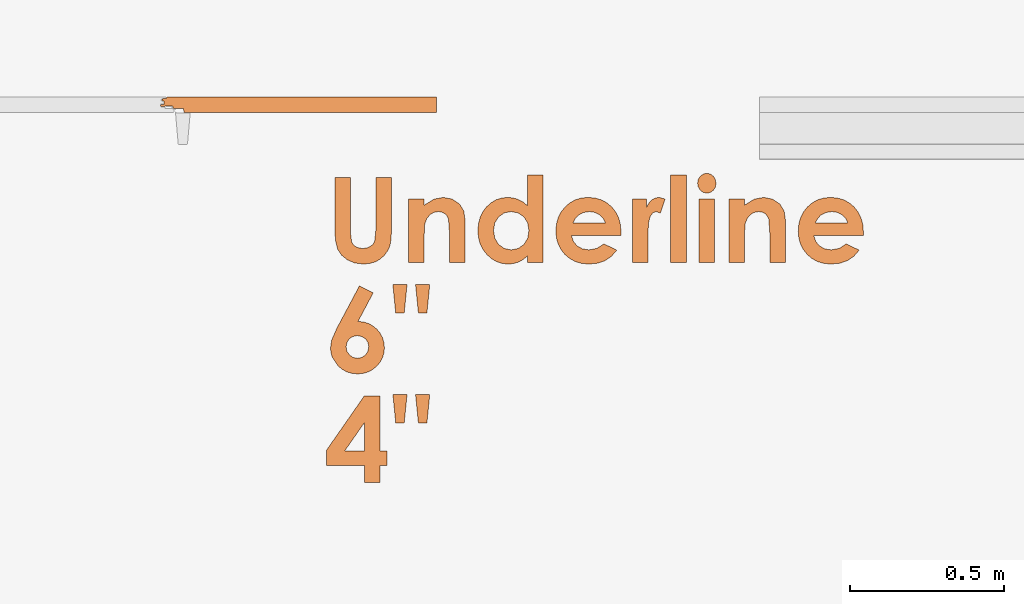
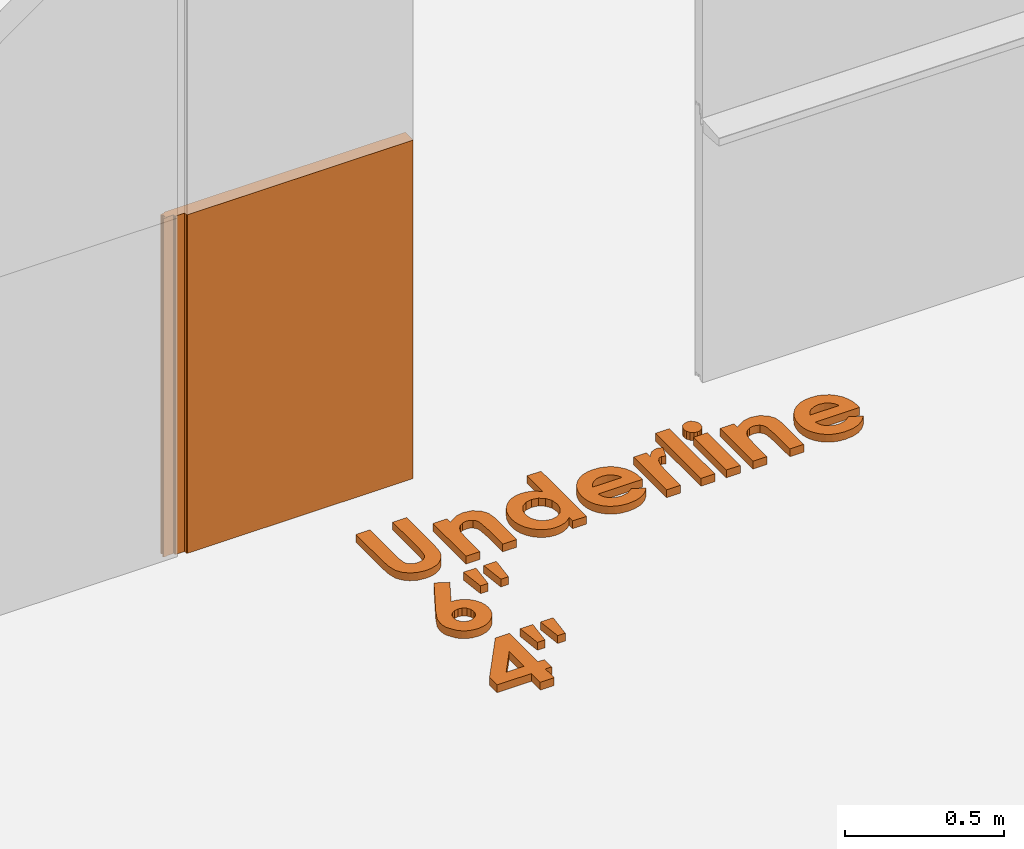
# One storey, part 4 of 6: 2 proxies.
"""IFC2X3 building model written with IfcOpenShell, lengths in millimetres."""

from ifc_helpers import new_model, entity, si_unit, converted_unit, derived_unit, direction, frame, frame_2d, origin, origin_2d_with_axis, place, context, subcontext, project, spatial, polyline, circle_curve, parameter, trimmed, segment, composite_curve, rectangle, outline, extrude, source, transform, mapped, material, type_object, type_shapes, element, save


model = new_model("IFC2X3")

# Units and contexts
model_context = context("Model", 3, precision=0.01, world=origin(), true_north=direction((6.123031769111886e-17, 1.0)))
body_context = subcontext(model_context, "Body", "Model", "MODEL_VIEW")
ifc_project = project(units=[si_unit("LENGTHUNIT", "METRE", prefix="MILLI"), si_unit("AREAUNIT", "SQUARE_METRE"), si_unit("VOLUMEUNIT", "CUBIC_METRE"), converted_unit("PLANEANGLEUNIT", "DEGREE", entity("IfcPlaneAngleMeasure", 0.017453292519943278), si_unit("PLANEANGLEUNIT", "RADIAN"), dimensions=[0, 0, 0, 0, 0, 0, 0]), si_unit("MASSUNIT", "GRAM", prefix="KILO"), derived_unit("MASSDENSITYUNIT", [(si_unit("MASSUNIT", "GRAM", prefix="KILO"), 1), (si_unit("LENGTHUNIT", "METRE"), -3)]), derived_unit("IONCONCENTRATIONUNIT", [(si_unit("MASSUNIT", "GRAM", prefix="KILO"), 1), (si_unit("LENGTHUNIT", "METRE"), -3)]), derived_unit("MOMENTOFINERTIAUNIT", [(si_unit("LENGTHUNIT", "METRE"), 4)]), si_unit("TIMEUNIT", "SECOND"), si_unit("FREQUENCYUNIT", "HERTZ"), si_unit("THERMODYNAMICTEMPERATUREUNIT", "DEGREE_CELSIUS"), derived_unit("THERMALTRANSMITTANCEUNIT", [(si_unit("MASSUNIT", "GRAM", prefix="KILO"), 1), (si_unit("THERMODYNAMICTEMPERATUREUNIT", "KELVIN"), -1), (si_unit("TIMEUNIT", "SECOND"), -3)]), derived_unit("THERMALCONDUCTANCEUNIT", [(si_unit("MASSUNIT", "GRAM", prefix="KILO"), 1), (si_unit("THERMODYNAMICTEMPERATUREUNIT", "KELVIN"), -1), (si_unit("TIMEUNIT", "SECOND"), -3), (si_unit("LENGTHUNIT", "METRE"), 1)]), derived_unit("VOLUMETRICFLOWRATEUNIT", [(si_unit("LENGTHUNIT", "METRE", prefix="DECI"), 3), (si_unit("TIMEUNIT", "SECOND"), -1)]), derived_unit("MASSFLOWRATEUNIT", [(si_unit("MASSUNIT", "GRAM", prefix="KILO"), 1), (si_unit("TIMEUNIT", "SECOND"), -1)]), derived_unit("ROTATIONALFREQUENCYUNIT", [(si_unit("TIMEUNIT", "SECOND"), -1)]), si_unit("ELECTRICCURRENTUNIT", "AMPERE"), si_unit("ELECTRICVOLTAGEUNIT", "VOLT"), si_unit("POWERUNIT", "WATT"), si_unit("FORCEUNIT", "NEWTON", prefix="KILO"), si_unit("ILLUMINANCEUNIT", "LUX"), si_unit("LUMINOUSFLUXUNIT", "LUMEN"), si_unit("LUMINOUSINTENSITYUNIT", "CANDELA"), si_unit("ENERGYUNIT", "JOULE"), derived_unit("USERDEFINED", [(si_unit("MASSUNIT", "GRAM", prefix="KILO"), -1), (si_unit("LENGTHUNIT", "METRE"), -2), (si_unit("TIMEUNIT", "SECOND"), 3), (si_unit("LUMINOUSFLUXUNIT", "LUMEN"), 1)]), derived_unit("USERDEFINED", [(si_unit("MASSUNIT", "GRAM", prefix="KILO"), 1), (si_unit("TIMEUNIT", "SECOND"), -3), (si_unit("LENGTHUNIT", "METRE"), 3), (si_unit("ELECTRICCURRENTUNIT", "AMPERE"), -2)]), derived_unit("SOUNDPOWERUNIT", [(si_unit("MASSUNIT", "GRAM", prefix="KILO"), 1), (si_unit("TIMEUNIT", "SECOND"), -3), (si_unit("LENGTHUNIT", "METRE"), 2)]), derived_unit("SOUNDPRESSUREUNIT", [(si_unit("MASSUNIT", "GRAM", prefix="KILO"), 1), (si_unit("LENGTHUNIT", "METRE"), -1), (si_unit("TIMEUNIT", "SECOND"), -2)]), derived_unit("LINEARVELOCITYUNIT", [(si_unit("LENGTHUNIT", "METRE"), 1), (si_unit("TIMEUNIT", "SECOND"), -1)]), si_unit("PRESSUREUNIT", "PASCAL"), derived_unit("USERDEFINED", [(si_unit("MASSUNIT", "GRAM", prefix="KILO"), 1), (si_unit("LENGTHUNIT", "METRE"), -2), (si_unit("TIMEUNIT", "SECOND"), -2)]), derived_unit("LINEARFORCEUNIT", [(si_unit("MASSUNIT", "GRAM", prefix="KILO"), 1), (si_unit("TIMEUNIT", "SECOND"), -2)]), derived_unit("PLANARFORCEUNIT", [(si_unit("MASSUNIT", "GRAM", prefix="KILO"), 1), (si_unit("LENGTHUNIT", "METRE"), -1), (si_unit("TIMEUNIT", "SECOND"), -2)]), derived_unit("SPECIFICHEATCAPACITYUNIT", [(si_unit("THERMODYNAMICTEMPERATUREUNIT", "KELVIN"), -1), (si_unit("LENGTHUNIT", "METRE"), 2), (si_unit("TIMEUNIT", "SECOND"), -2)]), derived_unit("HEATFLUXDENSITYUNIT", [(si_unit("MASSUNIT", "GRAM", prefix="KILO"), 1), (si_unit("TIMEUNIT", "SECOND"), -3)]), derived_unit("HEATINGVALUEUNIT", [(si_unit("LENGTHUNIT", "METRE"), 2), (si_unit("TIMEUNIT", "SECOND"), -2)]), derived_unit("VAPORPERMEABILITYUNIT", [(si_unit("LENGTHUNIT", "METRE"), -1), (si_unit("TIMEUNIT", "SECOND"), 1)]), derived_unit("DYNAMICVISCOSITYUNIT", [(si_unit("MASSUNIT", "GRAM", prefix="KILO"), 1), (si_unit("TIMEUNIT", "SECOND"), -1), (si_unit("LENGTHUNIT", "METRE"), -1)]), derived_unit("THERMALEXPANSIONCOEFFICIENTUNIT", [(si_unit("THERMODYNAMICTEMPERATUREUNIT", "KELVIN"), -1)]), derived_unit("MODULUSOFELASTICITYUNIT", [(si_unit("MASSUNIT", "GRAM", prefix="KILO"), 1), (si_unit("LENGTHUNIT", "METRE"), -1), (si_unit("TIMEUNIT", "SECOND"), -2)]), derived_unit("ISOTHERMALMOISTURECAPACITYUNIT", [(si_unit("MASSUNIT", "GRAM", prefix="KILO"), -1), (si_unit("LENGTHUNIT", "METRE"), 3)]), derived_unit("MOISTUREDIFFUSIVITYUNIT", [(si_unit("TIMEUNIT", "SECOND"), -1), (si_unit("LENGTHUNIT", "METRE"), 2)]), derived_unit("MASSPERLENGTHUNIT", [(si_unit("MASSUNIT", "GRAM", prefix="KILO"), 1), (si_unit("LENGTHUNIT", "METRE"), -1)]), derived_unit("THERMALRESISTANCEUNIT", [(si_unit("MASSUNIT", "GRAM", prefix="KILO"), -1), (si_unit("TIMEUNIT", "SECOND"), 3), (si_unit("THERMODYNAMICTEMPERATUREUNIT", "KELVIN"), 1)]), derived_unit("ACCELERATIONUNIT", [(si_unit("LENGTHUNIT", "METRE"), 1), (si_unit("TIMEUNIT", "SECOND"), -2)]), derived_unit("ANGULARVELOCITYUNIT", [(si_unit("TIMEUNIT", "SECOND"), -1), (si_unit("PLANEANGLEUNIT", "RADIAN"), 1)]), derived_unit("LINEARSTIFFNESSUNIT", [(si_unit("MASSUNIT", "GRAM", prefix="KILO"), 1), (si_unit("TIMEUNIT", "SECOND"), -2)]), derived_unit("WARPINGCONSTANTUNIT", [(si_unit("LENGTHUNIT", "METRE"), 6)]), derived_unit("LINEARMOMENTUNIT", [(si_unit("MASSUNIT", "GRAM", prefix="KILO"), 1), (si_unit("LENGTHUNIT", "METRE"), 1), (si_unit("TIMEUNIT", "SECOND"), -2)]), derived_unit("TORQUEUNIT", [(si_unit("MASSUNIT", "GRAM", prefix="KILO"), 1), (si_unit("LENGTHUNIT", "METRE"), 2), (si_unit("TIMEUNIT", "SECOND"), -2)])], contexts=[model_context])

# Site, building, storey
site_placement = place(None, origin())
site = spatial("IfcSite", under=ifc_project, at=site_placement, CompositionType="ELEMENT")
building_placement = place(site_placement, origin())
building = spatial("IfcBuilding", under=site, at=building_placement, Name="de", CompositionType="ELEMENT")
storey_placement = place(building_placement, origin())
storey = spatial("IfcBuildingStorey", under=building, at=storey_placement, CompositionType="ELEMENT", Elevation=0.0)

# Proxies
building_element_proxy_type_1 = type_object("IfcBuildingElementProxyType", Name="Texto do modelo:280mm Arial", PredefinedType="NOTDEFINED")
proxy_1_placement = place(storey_placement, origin())
element("IfcBuildingElementProxy", 1, at=proxy_1_placement, inside=storey, type_object=building_element_proxy_type_1, Name="Texto do modelo:280mm Arial", ObjectType="Texto do modelo:280mm Arial", context=body_context, shape_type="SweptSolid", body=[
    extrude(outline(polyline([(-197.135076634808, -96.36871776231979), (-33.485153354831525, -96.36871776231979), (8.490691504096427, -94.00768913350116), (36.228272112894174, -86.92460324704406), (55.12551270309856, -74.35347753253053), (70.58033750624617, -55.52832941954201), (80.88055018846063, -31.638684782140214), (84.31395441586547, -3.8740694943865037), (82.52065404512129, 17.31210724742106), (77.14075293288862, 35.74074673572234), (68.02105456508377, 51.79033447590066), (55.00836242762312, 65.83935597333932), (39.7788266157751, 76.78840095049625), (24.008597224808227, 83.53805912983013), (1.6148714896352496, 87.0255327151469), (-33.48515335483111, 88.18802391025248), (-197.13507663480766, 88.18802391025248), (-197.13507663480766, 37.43491995029546), (-26.27590563324637, 37.43491995029546), (11.104043803171214, 33.505879942031214), (20.0164762989805, 27.99981699467074), (27.21671246091335, 19.339708169116868), (31.974815957159343, 8.129327962052434), (33.56085045590794, -5.027549129839993), (32.137024030894906, -17.454489889921938), (27.865544755855876, -27.916910645871965), (21.224025292345775, -36.05434901161082), (12.690078301919677, -41.506342601059366), (-19.71549020660429, -45.61561380236263), (-197.13507663480794, -45.61561380236263), (-197.135076634808, -96.36871776231979)])), frame((-964.6189133034394, 358.32084995710176, 0.0), z_axis=(0.0, 0.0, 1.0), x_axis=(0.0, -1.0, 0.0)), (0.0, 0.0, 1.0), 30.0),
    extrude(outline(polyline([(-71.39783615934202, -98.70323738649664), (136.2284982223022, -98.70323738649664), (136.2284982223022, -47.950133426539615), (52.52913217470197, -47.950133426539615), (10.138755571782912, -45.571081678416384), (-6.577687582641928, -39.299036160637435), (-19.238928893675357, -29.422366782066188), (-27.214159185678575, -16.589905837645162), (-29.872569283012982, -1.4504856223168858), (-28.268511664960318, 10.147391649782836), (-23.4563388108024, 19.708656440534785), (-15.580235674970927, 26.971973520031455), (-4.784387211897605, 31.676007658365595), (44.81523711260633, 35.10040032611834), (136.2284982223025, 35.10040032611834), (136.2284982223025, 85.85350428607563), (-0.5309310561623658, 85.85350428607563), (-31.909181764360483, 81.27563198286954), (-54.52819649083311, 67.54201507325044), (-70.64086514857532, 43.33696584802934), (-76.01175470115618, 14.409859365169904), (-70.4245877169279, -15.436426202191265), (-50.56311024396169, -47.95013342653921), (-71.39783615934196, -47.95013342653921), (-71.39783615934202, -98.70323738649664)])), frame((-722.3606295049182, 414.84931230535244, 0.0), z_axis=(0.0, 0.0, 1.0), x_axis=(0.0, -1.0, 0.0)), (0.0, 0.0, 1.0), 30.0),
    extrude(outline(polyline([(-176.88914738248164, -74.5128578409968), (-176.88914738248155, -125.26596180095369), (109.17380221000593, -125.26596180095369), (109.17380221000593, -74.51285784099612), (87.69024399968303, -74.51285784099612), (99.60352585960199, -59.35541450636392), (107.65986018847306, -44.16192493312386), (112.25575561098339, -28.30157994563707), (113.78772075182013, -11.143570368265157), (111.85023542664413, 8.118638387844397), (106.0377794511163, 26.038124755808802), (96.3503528252366, 42.61488873562806), (82.78795554900499, 57.84893032730203), (66.34636496396548, 70.59127567520328), (48.02135841166193, 79.69295092370415), (27.81293589209434, 85.1539560728046), (5.721097405262716, 86.97429112250475), (-17.06688406468445, 85.21253121054244), (-37.70560855763416, 79.92725147465544), (-56.195076073586264, 71.11845191484387), (-72.53528661254099, 58.78613253110769), (-85.89267090668989, 43.939588004468874), (-95.43365968822485, 27.588113015949066), (-101.1582529571458, 9.73170756554855), (-103.06645071345274, -9.629628346732817), (-101.3722774988803, -27.598678292783028), (-96.28975785516296, -44.45029484198767), (-87.81889178230068, -60.112385517130704), (-75.95967928029351, -74.5128578409968), (-176.88914738248164, -74.5128578409968)]), holes=[polyline([(-56.92726529530953, -20.948147269620893), (-52.583693543054785, 1.5627287410278248), (-39.552978286290134, 19.928287311765285), (-19.727547051931783, 32.14796219985171), (5.000172633104336, 36.22118716254725), (29.908123511180083, 32.07586972263599), (49.98587841579391, 19.63991740290215), (63.23287110420619, 1.1481969970369155), (67.64853533367699, -21.164424701268178), (63.30496358142218, -44.04477465764818), (50.27424832465753, -62.653645338989165), (30.21451653934769, -75.00849362185525), (4.783895201457053, -79.12677638281076), (-20.142078795922625, -75.0084936218554), (-39.84134819515334, -62.6536453389893), (-52.655786020270504, -43.99070529973667), (-56.92726529530953, -20.948147269620893)])]), frame((-508.0075672200088, 387.79461629305536, 0.0), z_axis=(0.0, 0.0, -1.0), x_axis=(0.0, -1.0, 0.0)), (0.0, 0.0, -1.0), 30.0),
    extrude(outline(polyline([(-8.11404073497101, -112.03894976959059), (1.83707168478397, -112.03894976959056), (26.371906783790156, -109.63524336608025), (48.298315745056215, -103.54756103241345), (67.61629856858222, -93.77590276859067), (84.32585525436811, -80.32026857461125), (97.74060425866037, -63.948222802015096), (107.17416403770528, -45.427329802341696), (112.626534591503, -24.757589575590927), (114.09771592005353, -1.9390021217627762), (111.68181740608563, 19.528660321923912), (105.41027412957447, 39.02864344493145), (95.28308609052006, 56.56094724725969), (81.3002532889224, 72.12557172890877), (64.42784134457433, 84.8196152158297), (45.63191587726898, 93.74017603397405), (24.91247688700634, 98.88725418334141), (2.2695243737863007, 100.2608496639319), (-19.751728434694087, 97.91403977589047), (-39.75927548141036, 91.87483209825997), (-57.75311676636253, 82.14322663104068), (-73.73325228955056, 68.71922337423254), (-86.77033965545135, 52.389188970201), (-95.93503646854181, 33.93949006131208), (-101.22734272882185, 13.370126647565675), (-102.64725843629154, -9.31890127103823), (-99.26088751561832, -37.80065058597299), (-90.4336036871196, -61.981767588811785), (-75.92019374127064, -82.36168812962447), (-55.47544446854666, -99.43984805848197), (-35.92262886688955, -56.83072333122315), (-51.053380694864686, -35.00400568277521), (-56.503303033711035, -9.03686690864556), (-53.84238716741448, 12.437503644007833), (-44.8380484336359, 29.867423097071715), (-30.445286520588205, 42.402871219445984), (-11.619101116484497, 49.193827780030404), (-8.11404073497101, -112.03894976959059)]), holes=[polyline([(32.30305025346912, -60.611550644853786), (29.996635912124393, 45.483509056997775), (45.60841301373618, 37.18778165873086), (55.757341201558404, 28.088256327644583), (64.76912250878897, 11.590812985241655), (68.06970797756777, -7.554619648514906), (65.8874670985544, -25.340999198491758), (58.51971109543776, -40.93260300890451), (46.98528910236147, -53.099447888207074), (32.30305025346912, -60.611550644853786)])]), frame((-241.02849744432936, 376.8324445053329, 0.0), z_axis=(0.0, 0.0, 1.0), x_axis=(0.021733995409216757, 0.9997637888239163, 0.0)), (0.0, 0.0, 1.0), 30.0),
    extrude(outline(polyline([(-56.439928192101945, -57.358047093115275), (151.18640618954225, -57.358047093115275), (151.18640618954225, -6.604943133158253), (67.84750252802124, -6.604943133158253), (57.82664819501829, -6.821220564805537), (21.744363348486033, -4.8927467992816105), (-0.13570348652401948, 0.8926744972903038), (-11.219921858460749, 9.453656166672568), (-14.91466131577297, 19.70881105062687), (-10.37283525117446, 33.69475163050152), (-55.64691094272738, 48.762079368613946), (-61.0538467339161, 29.729665383629957), (-59.00822269291643, 17.40185177971989), (-52.8713505699173, 6.083332856831612), (-42.78741531935052, -3.6491515673080706), (-28.900601895647686, -11.218861674972208), (-56.43992819210188, -11.218861674972208), (-56.439928192101945, -57.358047093115275)])), frame((-34.706690191637534, 429.80722027259094, 0.0), z_axis=(0.0, 0.0, 1.0), x_axis=(0.0, -1.0, 0.0)), (0.0, 0.0, 1.0), 30.0),
    extrude(rectangle(XDim=286.0629495924876, YDim=50.75310395995675, at=frame_2d((-2.842170943040401e-14, 0.0), x_axis=(1.0, 0.0))), frame((57.88761532421236, 421.65228887929214, 0.0), z_axis=(0.0, 0.0, 1.0), x_axis=(0.0, -1.0, 0.0)), (0.0, 0.0, 1.0), 30.0),
    extrude(outline(polyline([(-6.301712198753567, -31.60790630917671), (5.420899933632481, -31.60790630917671), (16.281580658394684, -26.689281867233216), (24.754440796515407, -17.940784070354724), (29.31359116897778, -6.451164005550097), (29.653716775795946, 6.407063642744563), (25.240729387126496, 18.130818809981875), (17.074846845138385, 27.12018522368942), (6.156286992001091, 31.775246611394653), (-5.412701256381329, 31.71657774984953), (-16.236472346675033, 26.70773668446727), (-24.732567265953474, 17.844415841171212), (-29.318527001289805, 6.22230764588482), (-29.63184324523399, -6.503431871928007), (-25.19562107540711, -18.112363992747763), (-17.066648167887497, -27.011513783016547), (-6.301712198753567, -31.60790630917671)])), frame((150.18626216971575, 537.0678391220397, 0.0), z_axis=(0.0, 0.0, 1.0), x_axis=(-0.9801346684953595, -0.19833313291906599, 0.0)), (0.0, 0.0, 1.0), 30.0),
    extrude(rectangle(XDim=207.62633438164426, YDim=50.75310395995702, at=origin_2d_with_axis()), frame((150.1659861604985, 382.4339812738703, 0.0), z_axis=(0.0, 0.0, 1.0), x_axis=(0.0, -1.0, 0.0)), (0.0, 0.0, 1.0), 30.0),
    extrude(outline(polyline([(-71.39783615934189, -98.70323738649637), (136.22849822230225, -98.70323738649637), (136.22849822230225, -47.950133426539615), (52.52913217470204, -47.950133426539615), (10.138755571783047, -45.571081678416114), (-6.57768758264186, -39.299036160637435), (-19.23892889367529, -29.422366782066188), (-27.214159185678508, -16.589905837645162), (-29.872569283012915, -1.4504856223168858), (-28.26851166496025, 10.147391649782836), (-23.456338810802333, 19.708656440534785), (-15.58023567497086, 26.971973520031455), (-4.784387211897537, 31.676007658365595), (44.815237112606404, 35.10040032611834), (136.22849822230256, 35.10040032611834), (136.22849822230256, 85.85350428607563), (-0.5309310561622981, 85.85350428607563), (-31.909181764360415, 81.27563198286954), (-54.52819649083305, 67.54201507325071), (-70.64086514857524, 43.33696584802961), (-76.01175470115605, 14.409859365170174), (-70.42458771692783, -15.436426202191265), (-50.56311024396162, -47.950133426539075), (-71.39783615934189, -47.950133426539075), (-71.39783615934189, -98.70323738649637)])), frame((320.38496094511726, 414.8493123053502, 0.0), z_axis=(0.0, 0.0, 1.0), x_axis=(0.0, -1.0, 0.0)), (0.0, 0.0, 1.0), 30.0),
    extrude(outline(polyline([(-8.114040734969551, -112.03894976959074), (1.8370716847854303, -112.03894976959074), (26.371906783791587, -109.63524336608019), (48.29831574505763, -103.54756103241314), (67.61629856858343, -93.77590276858986), (84.32585525436912, -80.32026857461013), (97.74060425866115, -63.94822280201382), (107.17416403770582, -45.42732980234031), (112.62653459150333, -24.75758957558961), (114.09771592005346, -1.9390021217617182), (111.68181740608529, 19.52866032192508), (105.41027412957395, 39.02864344493254), (95.28308609051923, 56.56094724726067), (81.30025328892135, 72.12557172890973), (64.42784134457311, 84.81961521583062), (45.63191587726764, 93.74017603397449), (24.91247688700493, 98.88725418334161), (2.269524373784868, 100.26084966393199), (-19.751728434695483, 97.91403977589019), (-39.759275481411684, 91.87483209825974), (-57.75311676636372, 82.14322663104008), (-73.73325228955156, 68.71922337423179), (-86.77033965545212, 52.38918897020023), (-95.93503646854226, 33.93949006131109), (-101.22734272882205, 13.370126647564621), (-102.64725843629147, -9.318901271039435), (-99.26088751561785, -37.80065058597402), (-90.43360368711878, -61.981767588812716), (-75.92019374126957, -82.36168812962552), (-55.47544446854537, -99.43984805848265), (-35.92262886688884, -56.830723331223616), (-51.05338069486428, -35.0040056827753), (-56.50330303371098, -9.036866908646118), (-53.84238716741472, 12.437503644007439), (-44.83804843363637, 29.867423097071146), (-30.445286520588848, 42.40287121944554), (-11.619101116485231, 49.19382778003008), (-8.114040734969551, -112.03894976959074)]), holes=[polyline([(32.30305025346987, -60.6115506448535), (29.9966359121237, 45.48350905699814), (45.60841301373561, 37.1877816587313), (55.757341201557956, 28.0882563276454), (64.76912250878873, 11.590812985242573), (68.0697079775678, -7.554619648514087), (65.88746709855467, -25.340999198490827), (58.51971109543825, -40.93260300890366), (46.98528910236219, -53.09944788820649), (32.30305025346987, -60.6115506448535)])]), frame((547.9515732059187, 376.8324445053312, 0.0), z_axis=(0.0, 0.0, 1.0), x_axis=(0.02173399540923035, 0.9997637888239159, 0.0)), (0.0, 0.0, 1.0), 30.0),
    extrude(outline(polyline([(-169.66183796967937, -98.99477912253916), (-15.146399701648281, -98.99477912253886), (27.878495229872524, -95.89960184133162), (52.121628786830605, -87.28397024366502), (65.6659704647548, -78.29373765017078), (76.89738450283843, -66.9717831427635), (92.421429659484, -37.332708386209944), (96.07797130501153, -20.23717390641826), (96.14940636462921, -3.25308905142279), (92.6357348383373, 13.619546178776623), (85.53695672613557, 30.38073178417967), (76.01873011613868, 44.989019629840946), (64.39991962930331, 56.99395784681484), (50.680525265629285, 66.39554643510155), (34.860547025116794, 73.19378539470105), (18.146112702035733, 76.96384004086377), (1.743350090656581, 77.28087568884037), (-14.347740809020715, 74.14489233863046), (-30.127159996996397, 67.55588999023439), (-44.92453947273135, 57.90384352385236), (-56.9239939241664, 46.188419116038254), (-66.12552335130152, 32.409616766792276), (-72.52912775413677, 16.56743647611421), (-75.85604852554286, -0.17401198811110782), (-75.82752705839061, -16.650618857999227), (-72.44356335268003, -32.862384133549995), (-65.70415740841104, -48.80930781476339), (-171.61654338207018, -48.82945594929495), (-169.66183796967937, -98.99477912253916)]), holes=[polyline([(-23.856885622150433, -29.23151012664523), (-28.502115401814958, -14.941580255402522), (-27.263265809341423, -0.5824437284030344), (-20.65922699055348, 12.058870921159274), (-9.208889091274667, 21.195335160090508), (5.061279462710555, 25.6667115977814), (19.48841173921792, 23.97404545675935), (32.171292427590174, 17.004207837394425), (41.208706217170366, 5.644069840056746), (45.25258229454968, -7.669449140961902), (43.700028097418254, -21.899506425450323), (36.96857923674712, -34.7617610110216), (25.47577132350722, -43.97187189528907), (11.540094598120449, -48.438762093508984), (-2.5199606989916377, -47.07135462093718), (-14.915314221268666, -40.46911534338025), (-23.856885622150433, -29.23151012664523)])]), frame((-973.29051186755, 6.128888372974831, 0.0), z_axis=(0.0, 0.0, 1.0), x_axis=(-0.4698373532774691, -0.8827530013912287, 0.0)), (0.0, 0.0, 1.0), 30.0),
    extrude(outline(polyline([(-44.53289925453546, -18.36408216681859), (48.205715687899236, -18.36408216681859), (43.61469514619443, 27.546123250228316), (-47.287511579558306, 9.18204108340953), (-44.53289925453546, -18.36408216681859)])), frame((-848.7473781423013, 160.88456319715382, 0.0), z_axis=(0.0, 0.0, 1.0), x_axis=(0.09950371902100134, 0.9950371902099889, 0.0)), (0.0, 0.0, 1.0), 30.0),
    extrude(outline(polyline([(-44.53289925453539, -18.36408216681879), (48.20571568789929, -18.36408216681879), (43.61469514619446, 27.546123250228117), (-47.28751157955828, 9.182041083409331), (-44.53289925453539, -18.36408216681879)])), frame((-774.9246814732725, 160.88456319715362, 0.0), z_axis=(0.0, 0.0, 1.0), x_axis=(0.09950371902100281, 0.9950371902099888, 0.0)), (0.0, 0.0, 1.0), 30.0),
    extrude(outline(polyline([(-143.95272402011778, -112.24896765787754), (72.83533661905689, -112.24896765787754), (112.35981574631157, -84.73557416491812), (41.18744455494363, 17.50738980498599), (86.62876187490123, 49.13955477892745), (57.632610648788415, 90.7940956555551), (12.191293328831039, 59.16193068161378), (-0.9887754103112381, 78.09581289826278), (-38.85653984360908, 51.73567541997834), (-25.676471104466877, 32.80179320332946), (-173.36075239432859, -70.00274296197995), (-143.95272402011778, -112.24896765787754)]), holes=[polyline([(3.3196801216458223, -8.852747673298262), (40.55337430972267, -62.34096493533157), (-73.5400480015635, -62.35558921125364), (3.3196801216458223, -8.852747673298262)])]), frame((-954.9330432196826, -337.526182834684, 0.0), z_axis=(0.0, 0.0, 1.0), x_axis=(-0.5713177907106903, -0.8207289333375887, 0.0)), (0.0, 0.0, 1.0), 29.999999999999975),
    extrude(outline(polyline([(-44.532899254535444, -18.364082166818722), (48.20571568789929, -18.36408216681872), (43.61469514619449, 27.546123250228188), (-47.28751157955833, 9.182041083409395), (-44.532899254535444, -18.364082166818722)])), frame((-848.7473781423022, -196.77545186308723, 0.0), z_axis=(0.0, 0.0, 1.0), x_axis=(0.09950371902100129, 0.9950371902099889, 0.0)), (0.0, 0.0, 1.0), 30.0),
    extrude(outline(polyline([(-44.53289925453544, -18.36408216681865), (48.20571568789932, -18.36408216681865), (43.61469514619446, 27.54612325022825), (-47.28751157955834, 9.182041083409327), (-44.53289925453544, -18.36408216681865)])), frame((-774.924681473273, -196.77545186308734, 0.0), z_axis=(0.0, 0.0, 1.0), x_axis=(0.09950371902100273, 0.9950371902099888, 0.0)), (0.0, 0.0, 1.0), 30.0),
])
ifc_material = material(Name="KSI_RAL9003")
building_element_proxy_type_2 = type_object("IfcBuildingElementProxyType", Name="Painel Evolution:Painel Evolution", PredefinedType="NOTDEFINED", material=ifc_material)
shared_shape = source(origin(), body_context, "Body", "SweptSolid", [
    extrude(outline(composite_curve([segment(trimmed(circle_curve(frame_2d((-78.46681410675188, 23.336917179009085), x_axis=(1.0, 0.0)), 1.9999999999995453), [parameter(90.00000000000202)], [parameter(180.00000000000017)], True, "PARAMETER"), True, "CONTINUOUS"), segment(polyline([(-80.46681410675154, 23.336917179009085), (-80.46681410675154, 21.936917179009303)]), True, "CONTINUOUS"), segment(trimmed(circle_curve(frame_2d((-82.46681410675268, 21.936917179009303), x_axis=(1.0, 0.0)), 2.0000000000000866), [parameter(269.99999999999795)], [parameter(359.99999999999966)], True, "PARAMETER"), False, "CONTINUOUS"), segment(polyline([(-82.46681410675268, 19.936917179009214), (-92.26681410675047, 19.936917179008116)]), True, "CONTINUOUS"), segment(trimmed(circle_curve(frame_2d((-92.26681410675036, 16.336917179008125), x_axis=(1.0, 0.0)), 3.599999999999723), [parameter(90.00000000000115)], [parameter(257.0000000000476)], True, "PARAMETER"), True, "CONTINUOUS"), segment(polyline([(-93.07663790238536, 12.829184945780879), (-89.54327023729223, 12.829184945780598)]), True, "CONTINUOUS"), segment(polyline([(-89.54327023729223, 12.829184945780598), (-89.54327023729223, 1.01878053063045)]), True, "CONTINUOUS"), segment(polyline([(-89.54327023729223, 1.01878053063045), (-97.38552178046922, 1.01878053063045)]), True, "CONTINUOUS"), segment(trimmed(circle_curve(frame_2d((-97.19447091755893, -2.2443226659628213), x_axis=(1.0, 0.0)), 3.268691313635463), [parameter(93.35077536730483)], [parameter(269.99999999999875)], True, "PARAMETER"), True, "CONTINUOUS"), segment(polyline([(-97.19447091755904, -5.513013979598285), (-88.84933396518676, -5.513013979598291)]), True, "CONTINUOUS"), segment(trimmed(circle_curve(frame_2d((-88.7543915128835, -3.1148926459794515), x_axis=(1.0, 0.0)), 2.4000000000014894), [parameter(267.7328243153002)], [parameter(297.61930533248795)], True, "PARAMETER"), True, "CONTINUOUS"), segment(trimmed(circle_curve(frame_2d((-89.18708471763392, -2.3925770596252445), x_axis=(1.0, 0.0)), 3.2409633915334344), [parameter(298.47719428652744)], [parameter(327.9498252388278)], True, "PARAMETER"), True, "CONTINUOUS"), segment(trimmed(circle_curve(frame_2d((-85.23402025792467, -5.1638023196296885), x_axis=(1.0, 0.0)), 1.6000000018797356), [parameter(89.9999999999977)], [parameter(138.9204453243419)], True, "PARAMETER"), False, "CONTINUOUS"), segment(polyline([(-85.23402025792467, -3.5638023177499525), (-63.19654547373415, -3.5638023177499525)]), True, "CONTINUOUS"), segment(trimmed(circle_curve(frame_2d((-63.19654547373358, -6.563802326130676), x_axis=(1.0, 0.0)), 3.000000008153628), [parameter(359.9999999999996)], [parameter(90.00000000000529)], True, "PARAMETER"), False, "CONTINUOUS"), segment(polyline([(-60.196545465580016, -6.563802326130677), (-60.19654546535287, -8.854362853616363)]), True, "CONTINUOUS"), segment(trimmed(circle_curve(frame_2d((-57.396545449608766, -8.854362853619273), x_axis=(1.0, 0.0)), 2.8000000157420852), [parameter(179.99999999997146)], [parameter(269.9999999999694)], True, "PARAMETER"), True, "CONTINUOUS"), segment(polyline([(-57.396545449610244, -11.654362869361355), (-27.409620051040463, -11.654362869364617)]), True, "CONTINUOUS"), segment(trimmed(circle_curve(frame_2d((-27.401773758699335, -13.654347478554893), x_axis=(1.0, 0.0)), 2.000000000331924), [parameter(37.497615099321145)], [parameter(90.2247802945533)], True, "PARAMETER"), False, "CONTINUOUS"), segment(trimmed(circle_curve(frame_2d((-27.423656690687494, -13.6711373950838), x_axis=(1.0, 0.0)), 2.0275819508977904), [parameter(5.000780525159224)], [parameter(37.49761508504483)], True, "PARAMETER"), False, "CONTINUOUS"), segment(polyline([(-25.40379270879106, -13.494394468085556), (-24.657289985790783, -22.025621037275446)]), True, "CONTINUOUS"), segment(trimmed(circle_curve(frame_2d((-21.778461886534444, -21.773716695676615), x_axis=(1.0, 0.0)), 2.889828199469197), [parameter(185.00078054365574)], [parameter(268.975379034322)], True, "PARAMETER"), True, "CONTINUOUS"), segment(polyline([(-21.830137957039312, -24.663082821003158), (797.5722480884465, -24.663082820993743)]), True, "CONTINUOUS"), segment(polyline([(797.5722480884465, -24.663082820993743), (797.5722480884465, 25.33691717901027)]), True, "CONTINUOUS"), segment(polyline([(797.5722480884465, 25.33691717901027), (-78.46681410675188, 25.336917179008648)]), True, "CONTINUOUS")], self_intersect=False)), frame((-437.5722483932463, -0.33691717901087714, 0.0)), (0.0, 0.0, 1.0), 1300.0000000000005),
])
type_shapes(building_element_proxy_type_2, [shared_shape])
proxy_2_placement = place(storey_placement, frame((-1090.0510342028451, 792.600779225854, 0.0)))
element("IfcBuildingElementProxy", 2, at=proxy_2_placement, inside=storey, type_object=building_element_proxy_type_2, material=ifc_material, Name="Painel Evolution:Painel Evolution", ObjectType="Painel Evolution:Painel Evolution", context=body_context, shape_type="MappedRepresentation", body=[
    mapped(shared_shape, transform((0.0, 0.0, 0.0), scale=1.0)),
])

save(model, "model.ifc")
